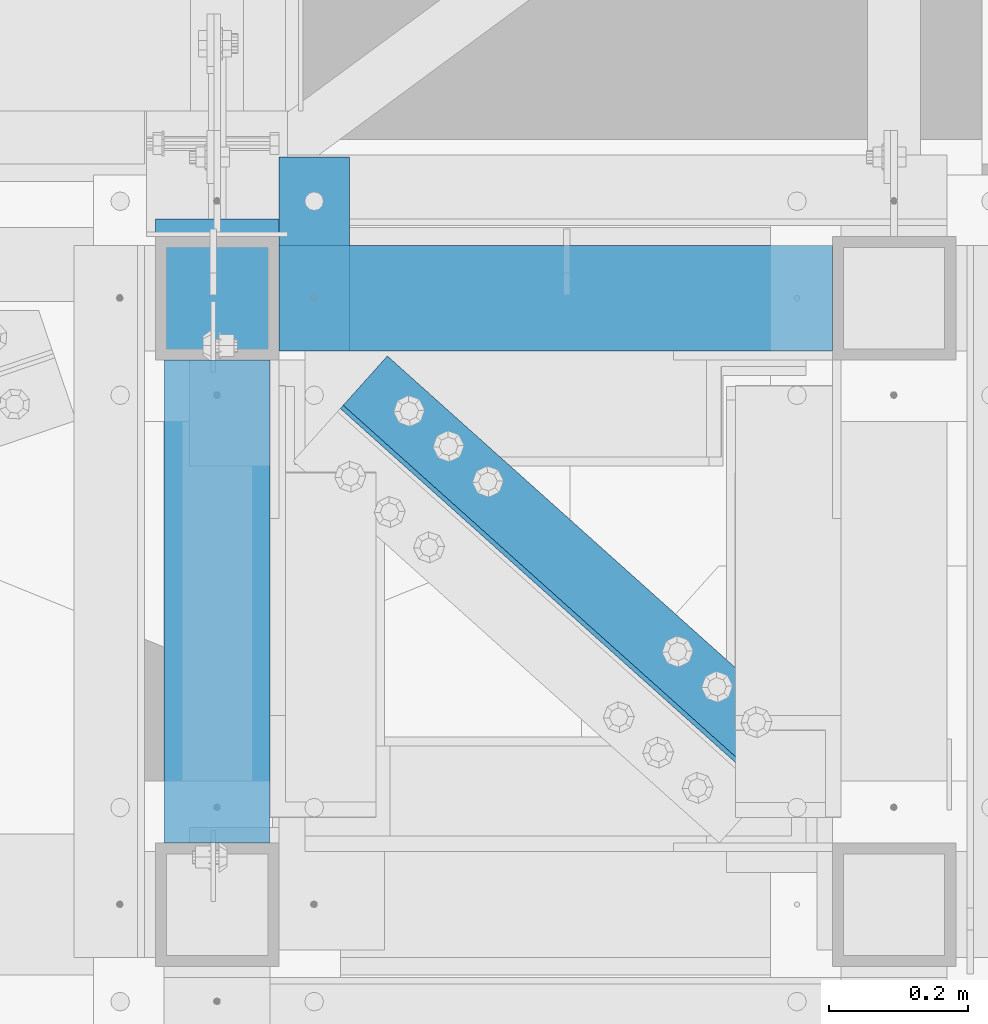
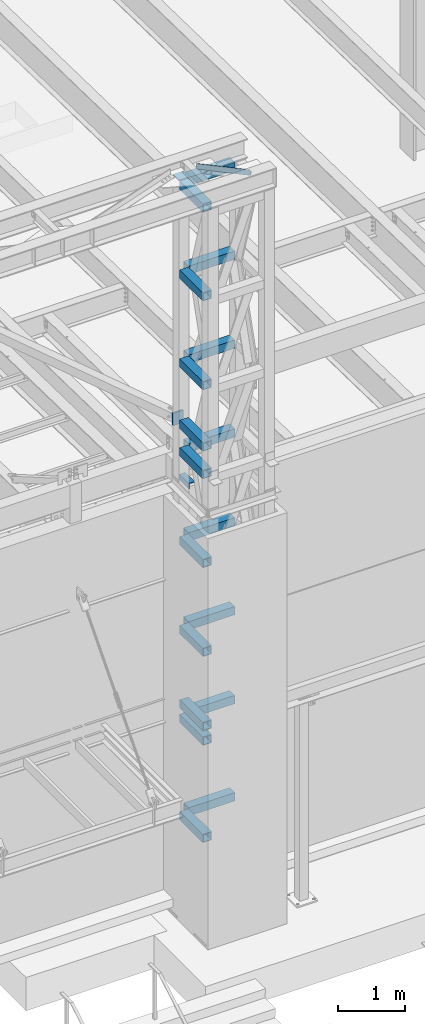
# One storey, part 1209 of 1763: 22 beams, 2 elements without a shape of their own.
"""IFC2X3 building model written with IfcOpenShell, lengths in millimetres."""

from ifc_helpers import new_model, si_unit, frame, origin_with_axes, place, context, subcontext, project, spatial, faceted_brep, material, type_object, element, aggregate, save


model = new_model("IFC2X3")

# Units and contexts
model_context = context("Model", 3, precision=1e-05, world=origin_with_axes())
body_context = subcontext(model_context, "Body", "Model", "MODEL_VIEW")
ifc_project = project(units=[si_unit("LENGTHUNIT", "METRE", prefix="MILLI"), si_unit("AREAUNIT", "SQUARE_METRE"), si_unit("VOLUMEUNIT", "CUBIC_METRE"), si_unit("MASSUNIT", "GRAM", prefix="KILO"), si_unit("TIMEUNIT", "SECOND"), si_unit("PLANEANGLEUNIT", "RADIAN"), si_unit("SOLIDANGLEUNIT", "STERADIAN"), si_unit("THERMODYNAMICTEMPERATUREUNIT", "DEGREE_CELSIUS"), si_unit("LUMINOUSINTENSITYUNIT", "LUMEN")], contexts=[model_context])

# Site, building, storey
site_placement = place(None, origin_with_axes())
site = spatial("IfcSite", under=ifc_project, at=site_placement, CompositionType="ELEMENT")
building_placement = place(site_placement, origin_with_axes())
building = spatial("IfcBuilding", under=site, at=building_placement, Name="Undefined", CompositionType="ELEMENT")
storey_placement = place(building_placement, origin_with_axes())
storey = spatial("IfcBuildingStorey", under=building, at=storey_placement, Name="Undefined", CompositionType="ELEMENT", Elevation=0.0)

# Assembly, beam
assembly_1_placement = place(storey_placement, origin_with_axes())
assembly_1 = element("IfcElementAssembly", 1, at=assembly_1_placement, inside=storey, Name="ANGLE", AssemblyPlace="NOTDEFINED", PredefinedType="RIGID_FRAME")
ifc_material_1 = material(Name="STEEL/A36")
beam_type_1 = type_object("IfcBeamType", Name="L4X4X1/4", PredefinedType="NOTDEFINED")
beam_1_placement = place(assembly_1_placement, frame((-47701.6352932414, -14541.760734232, 18672.175), z_axis=(0.667212485940871, 0.744867436933984, 0.0), x_axis=(0.744867436933985, -0.66721248594087, 0.0)))
beam_1 = element("IfcBeam", 2, at=beam_1_placement, type_object=beam_type_1, material=ifc_material_1, Name="ANGLE", ObjectType="L4X4X1/4", context=body_context, shape_type="Brep", body=[
    faceted_brep([(238.038898020732, -50.7999999999993, -44.4499999995751), (238.038898020724, -50.7999999999993, -50.7999999995664), (1061.95371877369, -50.7999999999993, -50.7999999982567), (1061.9537187737, -50.7999999999993, -44.4499999982654), (238.038898020732, 44.4500000000007, -44.4499999995751), (1061.9537187737, 44.4500000000007, -44.4499999982654), (238.038898020834, 44.4500000000007, 50.8000000003085), (1061.9537187738, 44.4500000000007, 50.8000000016182), (238.038898020834, 50.7999999999993, 50.8000000003085), (1061.9537187738, 50.7999999999993, 50.8000000016182), (238.038898020724, 50.7999999999993, -50.7999999995664), (1061.95371877369, 50.7999999999993, -50.7999999982567)], [[[0, 1, 2, 3]], [[4, 0, 3, 5]], [[6, 4, 5, 7]], [[8, 6, 7, 9]], [[1, 0, 4, 6, 8, 10]], [[1, 10, 11, 2]], [[7, 5, 3, 2, 11, 9]], [[10, 8, 9, 11]]]),
])
aggregate(assembly_1, [beam_1])

# Assembly, beams
assembly_2_placement = place(storey_placement, origin_with_axes())
assembly_2 = element("IfcElementAssembly", 3, at=assembly_2_placement, inside=storey, Name="FRAME", AssemblyPlace="NOTDEFINED", PredefinedType="RIGID_FRAME")
ifc_material_2 = material()
beam_type_2 = type_object("IfcBeamType", Name="HSS6X6X3/8", PredefinedType="NOTDEFINED")
beam_2_placement = place(assembly_2_placement, frame((-47735.5522038619, -15452.7271043647, 14001.749999), z_axis=(0.0, 0.0, 1.0), x_axis=(0.0, 1.0, 0.0)))
beam_2 = element("IfcBeam", 4, at=beam_2_placement, type_object=beam_type_2, material=ifc_material_2, Name="BEAM", ObjectType="HSS6X6X3/8", context=body_context, shape_type="Brep", body=[
    faceted_brep([(88.8999008650717, 66.6749999997191, -66.6749999999993), (88.8999007322054, -66.6750000002794, -66.6749999999993), (784.224900732206, -66.6750000025058, -66.6749999999993), (784.224900865072, 66.6749999974927, -66.6749999999993), (88.8999007322054, -66.6750000002794, 66.6749999999993), (784.224900732206, -66.6750000025058, 66.6749999999993), (88.8999008650717, 66.6749999997191, 66.6749999999993), (784.224900865072, 66.6749999974927, 66.6749999999993), (88.8999008745614, 76.1999999997206, -76.2000000000007), (88.8999008745614, 76.1999999997206, 76.2000000000007), (784.224900874562, 76.1999999974942, 76.2000000000007), (784.224900874562, 76.1999999974942, -76.2000000000007), (88.8999007227158, -76.2000000002809, 76.2000000000007), (784.224900722716, -76.2000000025073, 76.2000000000007), (88.8999007227158, -76.2000000002809, -76.2000000000007), (784.224900722716, -76.2000000025073, -76.2000000000007)], [[[0, 1, 2, 3]], [[1, 4, 5, 2]], [[4, 6, 7, 5]], [[6, 0, 3, 7]], [[8, 9, 10, 11]], [[9, 12, 13, 10]], [[12, 14, 15, 13]], [[14, 8, 11, 15]], [[13, 15, 11, 10], [5, 7, 3, 2]], [[14, 12, 9, 8], [6, 4, 1, 0]]]),
])
beam_3_placement = place(assembly_2_placement, frame((-47735.5522044142, -14579.6022094127, 10248.70156), z_axis=(0.0, 0.0, 1.0), x_axis=(0.99999999999718, 2.37500000002911e-06, 0.0)))
beam_3 = element("IfcBeam", 5, at=beam_3_placement, type_object=beam_type_2, material=ifc_material_2, Name="BEAM", ObjectType="HSS6X6X3/8", context=body_context, shape_type="Brep", body=[
    faceted_brep([(88.8999999999996, 66.6750000000029, -66.6749999999993), (88.8996463353687, -66.6749999999556, -66.6749999999993), (885.824841654605, -66.6750000000393, -66.6749999999993), (885.825158360378, 66.6749999998519, -66.6749999999993), (88.8996463353687, -66.6749999999556, 66.6749999999993), (885.824841654605, -66.6750000000393, 66.6749999999993), (88.8999999999996, 66.6750000000029, 66.6749999999993), (885.825158360378, 66.6749999998519, 66.6749999999993), (88.8999999999996, 76.1999999999971, -76.2000000000007), (88.8999999999996, 76.1999999999971, 76.2000000000007), (885.825180982218, 76.1999999998425, 76.2000000000007), (885.825180982218, 76.1999999998425, -76.2000000000007), (88.8996237135289, -76.1999999999498, 76.2000000000007), (885.824819032772, -76.2000000000335, 76.2000000000007), (88.8996237135289, -76.1999999999498, -76.2000000000007), (885.824819032772, -76.2000000000335, -76.2000000000007)], [[[0, 1, 2, 3]], [[1, 4, 5, 2]], [[4, 6, 7, 5]], [[6, 0, 3, 7]], [[8, 9, 10, 11]], [[9, 12, 13, 10]], [[12, 14, 15, 13]], [[14, 8, 11, 15]], [[13, 15, 11, 10], [5, 7, 3, 2]], [[14, 12, 9, 8], [6, 4, 1, 0]]]),
])
beam_4_placement = place(assembly_2_placement, frame((-47735.5522038619, -15452.7271043647, 10248.70156), z_axis=(0.0, 0.0, 1.0), x_axis=(0.0, 1.0, 0.0)))
beam_4 = element("IfcBeam", 6, at=beam_4_placement, type_object=beam_type_2, material=ifc_material_2, Name="BEAM", ObjectType="HSS6X6X3/8", context=body_context, shape_type="Brep", body=[
    faceted_brep([(88.8999008650717, 66.6749999997191, -66.6749999999993), (88.8999007322054, -66.6750000002794, -66.6749999999993), (784.224900732206, -66.6750000025058, -66.6749999999993), (784.224900865072, 66.6749999974927, -66.6749999999993), (88.8999007322054, -66.6750000002794, 66.6749999999993), (784.224900732206, -66.6750000025058, 66.6749999999993), (88.8999008650717, 66.6749999997191, 66.6749999999993), (784.224900865072, 66.6749999974927, 66.6749999999993), (88.8999008745614, 76.1999999997206, -76.2000000000007), (88.8999008745614, 76.1999999997206, 76.2000000000007), (784.224900874562, 76.1999999974942, 76.2000000000007), (784.224900874562, 76.1999999974942, -76.2000000000007), (88.8999007227158, -76.2000000002809, 76.2000000000007), (784.224900722716, -76.2000000025073, 76.2000000000007), (88.8999007227158, -76.2000000002809, -76.2000000000007), (784.224900722716, -76.2000000025073, -76.2000000000007)], [[[0, 1, 2, 3]], [[1, 4, 5, 2]], [[4, 6, 7, 5]], [[6, 0, 3, 7]], [[8, 9, 10, 11]], [[9, 12, 13, 10]], [[12, 14, 15, 13]], [[14, 8, 11, 15]], [[13, 15, 11, 10], [5, 7, 3, 2]], [[14, 12, 9, 8], [6, 4, 1, 0]]]),
])
beam_5_placement = place(assembly_2_placement, frame((-47735.5522044142, -14579.6022094127, 11873.706248), z_axis=(0.0, 0.0, 1.0), x_axis=(0.99999999999718, 2.37500000002911e-06, 0.0)))
beam_5 = element("IfcBeam", 7, at=beam_5_placement, type_object=beam_type_2, material=ifc_material_2, Name="BEAM", ObjectType="HSS6X6X3/8", context=body_context, shape_type="Brep", body=[
    faceted_brep([(88.8999999999996, 66.6750000000029, -66.6749999999993), (88.8996463353687, -66.6749999999556, -66.6749999999993), (885.824841654605, -66.6750000000393, -66.6749999999993), (885.825158360378, 66.6749999998519, -66.6749999999993), (88.8996463353687, -66.6749999999556, 66.6749999999993), (885.824841654605, -66.6750000000393, 66.6749999999993), (88.8999999999996, 66.6750000000029, 66.6749999999993), (885.825158360378, 66.6749999998519, 66.6749999999993), (88.8999999999996, 76.1999999999971, -76.2000000000007), (88.8999999999996, 76.1999999999971, 76.2000000000007), (885.825180982218, 76.1999999998425, 76.2000000000007), (885.825180982218, 76.1999999998425, -76.2000000000007), (88.8996237135289, -76.1999999999498, 76.2000000000007), (885.824819032772, -76.2000000000335, 76.2000000000007), (88.8996237135289, -76.1999999999498, -76.2000000000007), (885.824819032772, -76.2000000000335, -76.2000000000007)], [[[0, 1, 2, 3]], [[1, 4, 5, 2]], [[4, 6, 7, 5]], [[6, 0, 3, 7]], [[8, 9, 10, 11]], [[9, 12, 13, 10]], [[12, 14, 15, 13]], [[14, 8, 11, 15]], [[13, 15, 11, 10], [5, 7, 3, 2]], [[14, 12, 9, 8], [6, 4, 1, 0]]]),
])
beam_6_placement = place(assembly_2_placement, frame((-47735.5522038619, -15452.7271043647, 11873.706248), z_axis=(0.0, 0.0, 1.0), x_axis=(0.0, 1.0, 0.0)))
beam_6 = element("IfcBeam", 8, at=beam_6_placement, type_object=beam_type_2, material=ifc_material_2, Name="BEAM", ObjectType="HSS6X6X3/8", context=body_context, shape_type="Brep", body=[
    faceted_brep([(88.8999008650717, 66.6749999997191, -66.6749999999993), (88.8999007322054, -66.6750000002794, -66.6749999999993), (784.224900732206, -66.6750000025058, -66.6749999999993), (784.224900865072, 66.6749999974927, -66.6749999999993), (88.8999007322054, -66.6750000002794, 66.6749999999993), (784.224900732206, -66.6750000025058, 66.6749999999993), (88.8999008650717, 66.6749999997191, 66.6749999999993), (784.224900865072, 66.6749999974927, 66.6749999999993), (88.8999008745614, 76.1999999997206, -76.2000000000007), (88.8999008745614, 76.1999999997206, 76.2000000000007), (784.224900874562, 76.1999999974942, 76.2000000000007), (784.224900874562, 76.1999999974942, -76.2000000000007), (88.8999007227158, -76.2000000002809, 76.2000000000007), (784.224900722716, -76.2000000025073, 76.2000000000007), (88.8999007227158, -76.2000000002809, -76.2000000000007), (784.224900722716, -76.2000000025073, -76.2000000000007)], [[[0, 1, 2, 3]], [[1, 4, 5, 2]], [[4, 6, 7, 5]], [[6, 0, 3, 7]], [[8, 9, 10, 11]], [[9, 12, 13, 10]], [[12, 14, 15, 13]], [[14, 8, 11, 15]], [[13, 15, 11, 10], [5, 7, 3, 2]], [[14, 12, 9, 8], [6, 4, 1, 0]]]),
])
beam_7_placement = place(assembly_2_placement, frame((-47735.5522044142, -14579.6022094127, 13498.710936), z_axis=(0.0, 0.0, 1.0), x_axis=(0.99999999999718, 2.37500000002911e-06, 0.0)))
beam_7 = element("IfcBeam", 9, at=beam_7_placement, type_object=beam_type_2, material=ifc_material_2, Name="BEAM", ObjectType="HSS6X6X3/8", context=body_context, shape_type="Brep", body=[
    faceted_brep([(88.8999999999996, 66.6750000000029, -66.6749999999993), (88.8996463353687, -66.6749999999556, -66.6749999999993), (885.824841654605, -66.6750000000393, -66.6749999999993), (885.825158360378, 66.6749999998519, -66.6749999999993), (88.8996463353687, -66.6749999999556, 66.6749999999993), (885.824841654605, -66.6750000000393, 66.6749999999993), (88.8999999999996, 66.6750000000029, 66.6749999999993), (885.825158360378, 66.6749999998519, 66.6749999999993), (88.8999999999996, 76.1999999999971, -76.2000000000007), (88.8999999999996, 76.1999999999971, 76.2000000000007), (885.825180982218, 76.1999999998425, 76.2000000000007), (885.825180982218, 76.1999999998425, -76.2000000000007), (88.8996237135289, -76.1999999999498, 76.2000000000007), (885.824819032772, -76.2000000000335, 76.2000000000007), (88.8996237135289, -76.1999999999498, -76.2000000000007), (885.824819032772, -76.2000000000335, -76.2000000000007)], [[[0, 1, 2, 3]], [[1, 4, 5, 2]], [[4, 6, 7, 5]], [[6, 0, 3, 7]], [[8, 9, 10, 11]], [[9, 12, 13, 10]], [[12, 14, 15, 13]], [[14, 8, 11, 15]], [[13, 15, 11, 10], [5, 7, 3, 2]], [[14, 12, 9, 8], [6, 4, 1, 0]]]),
])
beam_8_placement = place(assembly_2_placement, frame((-47735.5522038619, -15452.7271043647, 13498.710936), z_axis=(0.0, 0.0, 1.0), x_axis=(0.0, 1.0, 0.0)))
beam_8 = element("IfcBeam", 10, at=beam_8_placement, type_object=beam_type_2, material=ifc_material_2, Name="BEAM", ObjectType="HSS6X6X3/8", context=body_context, shape_type="Brep", body=[
    faceted_brep([(88.8999008650717, 66.6749999997191, -66.6749999999993), (88.8999007322054, -66.6750000002794, -66.6749999999993), (784.224900732206, -66.6750000025058, -66.6749999999993), (784.224900865072, 66.6749999974927, -66.6749999999993), (88.8999007322054, -66.6750000002794, 66.6749999999993), (784.224900732206, -66.6750000025058, 66.6749999999993), (88.8999008650717, 66.6749999997191, 66.6749999999993), (784.224900865072, 66.6749999974927, 66.6749999999993), (88.8999008745614, 76.1999999997206, -76.2000000000007), (88.8999008745614, 76.1999999997206, 76.2000000000007), (784.224900874562, 76.1999999974942, 76.2000000000007), (784.224900874562, 76.1999999974942, -76.2000000000007), (88.8999007227158, -76.2000000002809, 76.2000000000007), (784.224900722716, -76.2000000025073, 76.2000000000007), (88.8999007227158, -76.2000000002809, -76.2000000000007), (784.224900722716, -76.2000000025073, -76.2000000000007)], [[[0, 1, 2, 3]], [[1, 4, 5, 2]], [[4, 6, 7, 5]], [[6, 0, 3, 7]], [[8, 9, 10, 11]], [[9, 12, 13, 10]], [[12, 14, 15, 13]], [[14, 8, 11, 15]], [[13, 15, 11, 10], [5, 7, 3, 2]], [[14, 12, 9, 8], [6, 4, 1, 0]]]),
])
beam_9_placement = place(assembly_2_placement, frame((-47735.5522044142, -14579.6022094127, 15123.715624), z_axis=(0.0, 0.0, 1.0), x_axis=(0.99999999999718, 2.37500000002911e-06, 0.0)))
beam_9 = element("IfcBeam", 11, at=beam_9_placement, type_object=beam_type_2, material=ifc_material_2, Name="BEAM", ObjectType="HSS6X6X3/8", context=body_context, shape_type="Brep", body=[
    faceted_brep([(88.8999999999996, 66.6750000000029, -66.6749999999993), (88.8996463353687, -66.6749999999556, -66.6749999999993), (885.824841654605, -66.6750000000393, -66.6749999999993), (885.825158360378, 66.6749999998519, -66.6749999999993), (88.8996463353687, -66.6749999999556, 66.6749999999993), (885.824841654605, -66.6750000000393, 66.6749999999993), (88.8999999999996, 66.6750000000029, 66.6749999999993), (885.825158360378, 66.6749999998519, 66.6749999999993), (88.8999999999996, 76.1999999999971, -76.2000000000007), (88.8999999999996, 76.1999999999971, 76.2000000000007), (885.825180982218, 76.1999999998425, 76.2000000000007), (885.825180982218, 76.1999999998425, -76.2000000000007), (88.8996237135289, -76.1999999999498, 76.2000000000007), (885.824819032772, -76.2000000000335, 76.2000000000007), (88.8996237135289, -76.1999999999498, -76.2000000000007), (885.824819032772, -76.2000000000335, -76.2000000000007)], [[[0, 1, 2, 3]], [[1, 4, 5, 2]], [[4, 6, 7, 5]], [[6, 0, 3, 7]], [[8, 9, 10, 11]], [[9, 12, 13, 10]], [[12, 14, 15, 13]], [[14, 8, 11, 15]], [[13, 15, 11, 10], [5, 7, 3, 2]], [[14, 12, 9, 8], [6, 4, 1, 0]]]),
])
beam_10_placement = place(assembly_2_placement, frame((-47735.5522038619, -15452.7271043647, 15123.715624), z_axis=(0.0, 0.0, 1.0), x_axis=(0.0, 1.0, 0.0)))
beam_10 = element("IfcBeam", 12, at=beam_10_placement, type_object=beam_type_2, material=ifc_material_2, Name="BEAM", ObjectType="HSS6X6X3/8", context=body_context, shape_type="Brep", body=[
    faceted_brep([(88.8999008650717, 66.6749999997191, -66.6749999999993), (88.8999007322054, -66.6750000002794, -66.6749999999993), (784.224900732206, -66.6750000025058, -66.6749999999993), (784.224900865072, 66.6749999974927, -66.6749999999993), (88.8999007322054, -66.6750000002794, 66.6749999999993), (784.224900732206, -66.6750000025058, 66.6749999999993), (88.8999008650717, 66.6749999997191, 66.6749999999993), (784.224900865072, 66.6749999974927, 66.6749999999993), (88.8999008745614, 76.1999999997206, -76.2000000000007), (88.8999008745614, 76.1999999997206, 76.2000000000007), (784.224900874562, 76.1999999974942, 76.2000000000007), (784.224900874562, 76.1999999974942, -76.2000000000007), (88.8999007227158, -76.2000000002809, 76.2000000000007), (784.224900722716, -76.2000000025073, 76.2000000000007), (88.8999007227158, -76.2000000002809, -76.2000000000007), (784.224900722716, -76.2000000025073, -76.2000000000007)], [[[0, 1, 2, 3]], [[1, 4, 5, 2]], [[4, 6, 7, 5]], [[6, 0, 3, 7]], [[8, 9, 10, 11]], [[9, 12, 13, 10]], [[12, 14, 15, 13]], [[14, 8, 11, 15]], [[13, 15, 11, 10], [5, 7, 3, 2]], [[14, 12, 9, 8], [6, 4, 1, 0]]]),
])
beam_11_placement = place(assembly_2_placement, frame((-47735.5522044142, -14579.6022094127, 16748.720312), z_axis=(0.0, 0.0, 1.0), x_axis=(0.99999999999718, 2.37500000002911e-06, 0.0)))
beam_11 = element("IfcBeam", 13, at=beam_11_placement, type_object=beam_type_2, material=ifc_material_2, Name="BEAM", ObjectType="HSS6X6X3/8", context=body_context, shape_type="Brep", body=[
    faceted_brep([(88.8999999999996, 66.6750000000029, -66.6749999999993), (88.8996463353687, -66.6749999999556, -66.6749999999993), (885.824841654605, -66.6750000000393, -66.6749999999993), (885.825158360378, 66.6749999998519, -66.6749999999993), (88.8996463353687, -66.6749999999556, 66.6749999999993), (885.824841654605, -66.6750000000393, 66.6749999999993), (88.8999999999996, 66.6750000000029, 66.6749999999993), (885.825158360378, 66.6749999998519, 66.6749999999993), (88.8999999999996, 76.1999999999971, -76.2000000000007), (88.8999999999996, 76.1999999999971, 76.2000000000007), (885.825180982218, 76.1999999998425, 76.2000000000007), (885.825180982218, 76.1999999998425, -76.2000000000007), (88.8996237135289, -76.1999999999498, 76.2000000000007), (885.824819032772, -76.2000000000335, 76.2000000000007), (88.8996237135289, -76.1999999999498, -76.2000000000007), (885.824819032772, -76.2000000000335, -76.2000000000007)], [[[0, 1, 2, 3]], [[1, 4, 5, 2]], [[4, 6, 7, 5]], [[6, 0, 3, 7]], [[8, 9, 10, 11]], [[9, 12, 13, 10]], [[12, 14, 15, 13]], [[14, 8, 11, 15]], [[13, 15, 11, 10], [5, 7, 3, 2]], [[14, 12, 9, 8], [6, 4, 1, 0]]]),
])
beam_12_placement = place(assembly_2_placement, frame((-47735.5522038619, -15452.7271043647, 16748.720312), z_axis=(0.0, 0.0, 1.0), x_axis=(0.0, 1.0, 0.0)))
beam_12 = element("IfcBeam", 14, at=beam_12_placement, type_object=beam_type_2, material=ifc_material_2, Name="BEAM", ObjectType="HSS6X6X3/8", context=body_context, shape_type="Brep", body=[
    faceted_brep([(88.8999008650717, 66.6749999997191, -66.6749999999993), (88.8999007322054, -66.6750000002794, -66.6749999999993), (784.224900732206, -66.6750000025058, -66.6749999999993), (784.224900865072, 66.6749999974927, -66.6749999999993), (88.8999007322054, -66.6750000002794, 66.6749999999993), (784.224900732206, -66.6750000025058, 66.6749999999993), (88.8999008650717, 66.6749999997191, 66.6749999999993), (784.224900865072, 66.6749999974927, 66.6749999999993), (88.8999008745614, 76.1999999997206, -76.2000000000007), (88.8999008745614, 76.1999999997206, 76.2000000000007), (784.224900874562, 76.1999999974942, 76.2000000000007), (784.224900874562, 76.1999999974942, -76.2000000000007), (88.8999007227158, -76.2000000002809, 76.2000000000007), (784.224900722716, -76.2000000025073, 76.2000000000007), (88.8999007227158, -76.2000000002809, -76.2000000000007), (784.224900722716, -76.2000000025073, -76.2000000000007)], [[[0, 1, 2, 3]], [[1, 4, 5, 2]], [[4, 6, 7, 5]], [[6, 0, 3, 7]], [[8, 9, 10, 11]], [[9, 12, 13, 10]], [[12, 14, 15, 13]], [[14, 8, 11, 15]], [[13, 15, 11, 10], [5, 7, 3, 2]], [[14, 12, 9, 8], [6, 4, 1, 0]]]),
])
beam_13_placement = place(assembly_2_placement, frame((-47735.5522044142, -15452.7272094127, 8890.0), z_axis=(0.0, 0.0, 1.0), x_axis=(0.0, 1.0, 0.0)))
beam_13 = element("IfcBeam", 15, at=beam_13_placement, type_object=beam_type_2, material=ifc_material_2, Name="BEAM", ObjectType="HSS6X6X3/8", context=body_context, shape_type="Brep", body=[
    faceted_brep([(88.8999999999996, 66.6750000000029, -66.6749999999993), (88.8999999999996, -66.6750000000029, -66.6749999999993), (784.225, -66.6750000000029, -66.6749999999993), (784.225, 66.6750000000029, -66.6749999999993), (88.8999999999996, -66.6750000000029, 66.6749999999993), (784.225, -66.6750000000029, 66.6749999999993), (88.8999999999996, 66.6750000000029, 66.6749999999993), (784.225, 66.6750000000029, 66.6749999999993), (88.8999999999996, 76.1999999999971, -76.2000000000007), (88.8999999999996, 76.1999999999971, 76.2000000000007), (784.225, 76.1999999999971, 76.2000000000007), (784.225, 76.1999999999971, -76.2000000000007), (88.8999999999996, -76.1999999999971, 76.2000000000007), (784.225, -76.1999999999971, 76.2000000000007), (88.8999999999996, -76.1999999999971, -76.2000000000007), (784.225, -76.1999999999971, -76.2000000000007)], [[[0, 1, 2, 3]], [[1, 4, 5, 2]], [[4, 6, 7, 5]], [[6, 0, 3, 7]], [[8, 9, 10, 11]], [[9, 12, 13, 10]], [[12, 14, 15, 13]], [[14, 8, 11, 15]], [[13, 15, 11, 10], [5, 7, 3, 2]], [[14, 12, 9, 8], [6, 4, 1, 0]]]),
])
beam_14_placement = place(assembly_2_placement, frame((-47735.5522044142, -14579.6022094127, 18373.725), z_axis=(0.0, 0.0, 1.0), x_axis=(0.99999999999718, 2.37500000002911e-06, 0.0)))
beam_14 = element("IfcBeam", 16, at=beam_14_placement, type_object=beam_type_2, material=ifc_material_2, Name="BEAM", ObjectType="HSS6X6X3/8", context=body_context, shape_type="Brep", body=[
    faceted_brep([(88.8999999999996, 66.6750000000029, -66.6749999999993), (88.8996463353687, -66.6749999999556, -66.6749999999993), (885.824841654605, -66.6750000000393, -66.6749999999993), (885.825158360378, 66.6749999998519, -66.6749999999993), (88.8996463353687, -66.6749999999556, 66.6749999999993), (885.824841654605, -66.6750000000393, 66.6749999999993), (88.8999999999996, 66.6750000000029, 66.6749999999993), (885.825158360378, 66.6749999998519, 66.6749999999993), (88.8999999999996, 76.1999999999971, -76.2000000000007), (88.8999999999996, 76.1999999999971, 76.2000000000007), (885.825180982218, 76.1999999998425, 76.2000000000007), (885.825180982218, 76.1999999998425, -76.2000000000007), (88.8996237135289, -76.1999999999498, 76.2000000000007), (885.824819032772, -76.2000000000335, 76.2000000000007), (88.8996237135289, -76.1999999999498, -76.2000000000007), (885.824819032772, -76.2000000000335, -76.2000000000007)], [[[0, 1, 2, 3]], [[1, 4, 5, 2]], [[4, 6, 7, 5]], [[6, 0, 3, 7]], [[8, 9, 10, 11]], [[9, 12, 13, 10]], [[12, 14, 15, 13]], [[14, 8, 11, 15]], [[13, 15, 11, 10], [5, 7, 3, 2]], [[14, 12, 9, 8], [6, 4, 1, 0]]]),
])
beam_15_placement = place(assembly_2_placement, frame((-47735.5522038619, -15452.7271043647, 18373.725), z_axis=(0.0, 0.0, 1.0), x_axis=(0.0, 1.0, 0.0)))
beam_15 = element("IfcBeam", 17, at=beam_15_placement, type_object=beam_type_2, material=ifc_material_2, Name="BEAM", ObjectType="HSS6X6X3/8", context=body_context, shape_type="Brep", body=[
    faceted_brep([(88.8999008650717, 66.6749999997191, -66.6749999999993), (88.8999007322054, -66.6750000002794, -66.6749999999993), (784.224900732206, -66.6750000025058, -66.6749999999993), (784.224900865072, 66.6749999974927, -66.6749999999993), (88.8999007322054, -66.6750000002794, 66.6749999999993), (784.224900732206, -66.6750000025058, 66.6749999999993), (88.8999008650717, 66.6749999997191, 66.6749999999993), (784.224900865072, 66.6749999974927, 66.6749999999993), (88.8999008745614, 76.1999999997206, -76.2000000000007), (88.8999008745614, 76.1999999997206, 76.2000000000007), (784.224900874562, 76.1999999974942, 76.2000000000007), (784.224900874562, 76.1999999974942, -76.2000000000007), (88.8999007227158, -76.2000000002809, 76.2000000000007), (784.224900722716, -76.2000000025073, 76.2000000000007), (88.8999007227158, -76.2000000002809, -76.2000000000007), (784.224900722716, -76.2000000025073, -76.2000000000007)], [[[0, 1, 2, 3]], [[1, 4, 5, 2]], [[4, 6, 7, 5]], [[6, 0, 3, 7]], [[8, 9, 10, 11]], [[9, 12, 13, 10]], [[12, 14, 15, 13]], [[14, 8, 11, 15]], [[13, 15, 11, 10], [5, 7, 3, 2]], [[14, 12, 9, 8], [6, 4, 1, 0]]]),
])
beam_16_placement = place(assembly_2_placement, frame((-47735.5522044142, -14579.6022094127, 8623.3), z_axis=(0.0, 0.0, 1.0), x_axis=(0.99999999999718, 2.37500000002911e-06, 0.0)))
beam_16 = element("IfcBeam", 18, at=beam_16_placement, type_object=beam_type_2, material=ifc_material_2, Name="BEAM", ObjectType="HSS6X6X3/8", context=body_context, shape_type="Brep", body=[
    faceted_brep([(88.8999999999996, 66.6750000000029, -66.6749999999993), (88.8996463353687, -66.6749999999556, -66.6749999999993), (885.824841654605, -66.6750000000393, -66.6749999999993), (885.825158360378, 66.6749999998519, -66.6749999999993), (88.8996463353687, -66.6749999999556, 66.6749999999993), (885.824841654605, -66.6750000000393, 66.6749999999993), (88.8999999999996, 66.6750000000029, 66.6749999999993), (885.825158360378, 66.6749999998519, 66.6749999999993), (88.8999999999996, 76.1999999999971, -76.2000000000007), (88.8999999999996, 76.1999999999971, 76.2000000000007), (885.825180982218, 76.1999999998425, 76.2000000000007), (885.825180982218, 76.1999999998425, -76.2000000000007), (88.8996237135289, -76.1999999999498, 76.2000000000007), (885.824819032772, -76.2000000000335, 76.2000000000007), (88.8996237135289, -76.1999999999498, -76.2000000000007), (885.824819032772, -76.2000000000335, -76.2000000000007)], [[[0, 1, 2, 3]], [[1, 4, 5, 2]], [[4, 6, 7, 5]], [[6, 0, 3, 7]], [[8, 9, 10, 11]], [[9, 12, 13, 10]], [[12, 14, 15, 13]], [[14, 8, 11, 15]], [[13, 15, 11, 10], [5, 7, 3, 2]], [[14, 12, 9, 8], [6, 4, 1, 0]]]),
])
beam_17_placement = place(assembly_2_placement, frame((-47735.5522044142, -15452.7272094127, 8623.3), z_axis=(0.0, 0.0, 1.0), x_axis=(0.0, 1.0, 0.0)))
beam_17 = element("IfcBeam", 19, at=beam_17_placement, type_object=beam_type_2, material=ifc_material_2, Name="BEAM", ObjectType="HSS6X6X3/8", context=body_context, shape_type="Brep", body=[
    faceted_brep([(88.8999999999996, 66.6750000000029, -66.6749999999993), (88.8999999999996, -66.6750000000029, -66.6749999999993), (784.225, -66.6750000000029, -66.6749999999993), (784.225, 66.6750000000029, -66.6749999999993), (88.8999999999996, -66.6750000000029, 66.6749999999993), (784.225, -66.6750000000029, 66.6749999999993), (88.8999999999996, 66.6750000000029, 66.6749999999993), (784.225, 66.6750000000029, 66.6749999999993), (88.8999999999996, 76.1999999999971, -76.2000000000007), (88.8999999999996, 76.1999999999971, 76.2000000000007), (784.225, 76.1999999999971, 76.2000000000007), (784.225, 76.1999999999971, -76.2000000000007), (88.8999999999996, -76.1999999999971, 76.2000000000007), (784.225, -76.1999999999971, 76.2000000000007), (88.8999999999996, -76.1999999999971, -76.2000000000007), (784.225, -76.1999999999971, -76.2000000000007)], [[[0, 1, 2, 3]], [[1, 4, 5, 2]], [[4, 6, 7, 5]], [[6, 0, 3, 7]], [[8, 9, 10, 11]], [[9, 12, 13, 10]], [[12, 14, 15, 13]], [[14, 8, 11, 15]], [[13, 15, 11, 10], [5, 7, 3, 2]], [[14, 12, 9, 8], [6, 4, 1, 0]]]),
])
beam_18_placement = place(assembly_2_placement, frame((-47735.5522044142, -14579.6022094127, 6845.3), z_axis=(0.0, 0.0, 1.0), x_axis=(0.99999999999718, 2.37500000002911e-06, 0.0)))
beam_18 = element("IfcBeam", 20, at=beam_18_placement, type_object=beam_type_2, material=ifc_material_2, Name="BEAM", ObjectType="HSS6X6X3/8", context=body_context, shape_type="Brep", body=[
    faceted_brep([(88.8999999999996, 66.6750000000029, -66.6749999999993), (88.8996463353687, -66.6749999999556, -66.6749999999993), (885.824841654605, -66.6750000000393, -66.6749999999993), (885.825158360378, 66.6749999998519, -66.6749999999993), (88.8996463353687, -66.6749999999556, 66.6749999999993), (885.824841654605, -66.6750000000393, 66.6749999999993), (88.8999999999996, 66.6750000000029, 66.6749999999993), (885.825158360378, 66.6749999998519, 66.6749999999993), (88.8999999999996, 76.1999999999971, -76.2000000000007), (88.8999999999996, 76.1999999999971, 76.2000000000007), (885.825180982218, 76.1999999998425, 76.2000000000007), (885.825180982218, 76.1999999998425, -76.2000000000007), (88.8996237135289, -76.1999999999498, 76.2000000000007), (885.824819032772, -76.2000000000335, 76.2000000000007), (88.8996237135289, -76.1999999999498, -76.2000000000007), (885.824819032772, -76.2000000000335, -76.2000000000007)], [[[0, 1, 2, 3]], [[1, 4, 5, 2]], [[4, 6, 7, 5]], [[6, 0, 3, 7]], [[8, 9, 10, 11]], [[9, 12, 13, 10]], [[12, 14, 15, 13]], [[14, 8, 11, 15]], [[13, 15, 11, 10], [5, 7, 3, 2]], [[14, 12, 9, 8], [6, 4, 1, 0]]]),
])
beam_19_placement = place(assembly_2_placement, frame((-47735.5522044142, -15452.7272094127, 6845.3), z_axis=(0.0, 0.0, 1.0), x_axis=(0.0, 1.0, 0.0)))
beam_19 = element("IfcBeam", 21, at=beam_19_placement, type_object=beam_type_2, material=ifc_material_2, Name="BEAM", ObjectType="HSS6X6X3/8", context=body_context, shape_type="Brep", body=[
    faceted_brep([(88.8999999999996, 66.6750000000029, -66.6749999999993), (88.8999999999996, -66.6750000000029, -66.6749999999993), (784.225, -66.6750000000029, -66.6749999999993), (784.225, 66.6750000000029, -66.6749999999993), (88.8999999999996, -66.6750000000029, 66.6749999999993), (784.225, -66.6750000000029, 66.6749999999993), (88.8999999999996, 66.6750000000029, 66.6749999999993), (784.225, 66.6750000000029, 66.6749999999993), (88.8999999999996, 76.1999999999971, -76.2000000000007), (88.8999999999996, 76.1999999999971, 76.2000000000007), (784.225, 76.1999999999971, 76.2000000000007), (784.225, 76.1999999999971, -76.2000000000007), (88.8999999999996, -76.1999999999971, 76.2000000000007), (784.225, -76.1999999999971, 76.2000000000007), (88.8999999999996, -76.1999999999971, -76.2000000000007), (784.225, -76.1999999999971, -76.2000000000007)], [[[0, 1, 2, 3]], [[1, 4, 5, 2]], [[4, 6, 7, 5]], [[6, 0, 3, 7]], [[8, 9, 10, 11]], [[9, 12, 13, 10]], [[12, 14, 15, 13]], [[14, 8, 11, 15]], [[13, 15, 11, 10], [5, 7, 3, 2]], [[14, 12, 9, 8], [6, 4, 1, 0]]]),
])
beam_type_3 = type_object("IfcBeamType", PredefinedType="NOTDEFINED")
beam_20_placement = place(assembly_2_placement, frame((-47735.5634959181, -14478.0023133202, 14097.0459704449), z_axis=(1.0, 0.0, 0.0), x_axis=(0.0, 0.0, -1.0)))
beam_20 = element("IfcBeam", 22, at=beam_20_placement, type_object=beam_type_3, material=ifc_material_1, Name="PLATE", context=body_context, shape_type="Brep", body=[
    faceted_brep([(0.0, 12.7000000000007, -88.9000000000015), (0.0, 12.7000000000007, 88.9000000000015), (228.6, 12.7000000000007, 88.9000000000015), (228.6, 12.7000000000007, -88.9000000000015), (0.0, -12.7000000000007, 88.9000000000015), (228.6, -12.7000000000007, 88.9000000000015), (0.0, -12.7000000000007, -88.9000000000015), (228.6, -12.7000000000007, -88.9000000000015)], [[[0, 1, 2, 3]], [[1, 4, 5, 2]], [[4, 6, 7, 5]], [[6, 0, 3, 7]], [[5, 7, 3, 2]], [[6, 4, 1, 0]]]),
])
beam_type_4 = type_object("IfcBeamType", Name="L4X4X3/8", PredefinedType="NOTDEFINED")
beam_21_placement = place(assembly_2_placement, frame((-47595.8523997267, -14655.8022094127, 12801.6221257957), z_axis=(1.0, 0.0, 0.0), x_axis=(0.0, 1.0, 0.0)))
beam_21 = element("IfcBeam", 23, at=beam_21_placement, type_object=beam_type_4, material=ifc_material_1, Name="ANGLE", ObjectType="L4X4X3/8", context=body_context, shape_type="Brep", body=[
    faceted_brep([(-3.63797880709171e-11, 50.8000000000011, -50.8000000000538), (-1.96450855582952e-10, 50.8000000000393, 50.7999999999374), (279.4, 50.8000000000029, 50.7999999999993), (279.4, 50.8000000000029, -50.7999999999993), (0.0, 41.2749999999996, 50.7999999999993), (279.4, 41.2750000000015, 50.7999999999993), (0.0, 41.2749999999996, -41.2750000000015), (279.4, 41.2750000000015, -41.2749999999996), (0.0, -50.7999999999993, -41.2750000000015), (279.4, -50.8000000000029, -41.2749999999996), (2.11002770811319e-10, -50.8000000000357, -50.799999999952), (279.4, -50.8000000000029, -50.7999999999993)], [[[0, 1, 2, 3]], [[1, 4, 5, 2]], [[4, 6, 7, 5]], [[6, 8, 9, 7]], [[8, 10, 11, 9]], [[10, 0, 3, 11]], [[5, 7, 9, 11, 3, 2]], [[10, 8, 6, 4, 1, 0]]]),
])
beam_type_5 = type_object("IfcBeamType", PredefinedType="NOTDEFINED")
beam_22_placement = place(assembly_2_placement, frame((-47735.5523997267, -14668.5022094127, 18459.45), z_axis=(1.0, 0.0, 0.0), x_axis=(0.0, 1.0, 0.0)))
beam_22 = element("IfcBeam", 24, at=beam_22_placement, type_object=beam_type_5, material=ifc_material_1, Name="PLATE", context=body_context, shape_type="Brep", body=[
    faceted_brep([(0.0, 9.52500000000146, -88.9000000000015), (0.0, 9.52500000000146, 88.9000000000015), (177.799999999999, 9.52500000000146, 88.9000000000015), (177.799999999999, 9.52500000000146, -88.9000000000015), (0.0, -9.52500000000146, 88.9000000000015), (177.799999999999, -9.52500000000146, 88.9000000000015), (0.0, -9.52500000000146, -88.9000000000015), (177.799999999999, -9.52500000000146, -88.9000000000015)], [[[0, 1, 2, 3]], [[1, 4, 5, 2]], [[4, 6, 7, 5]], [[6, 0, 3, 7]], [[5, 7, 3, 2]], [[6, 4, 1, 0]]]),
])
aggregate(assembly_2, [beam_2, beam_20, beam_3, beam_4, beam_5, beam_6, beam_7, beam_8, beam_9, beam_10, beam_11, beam_12, beam_13, beam_14, beam_15, beam_16, beam_17, beam_18, beam_19, beam_21, beam_22])

save(model, "model.ifc")
